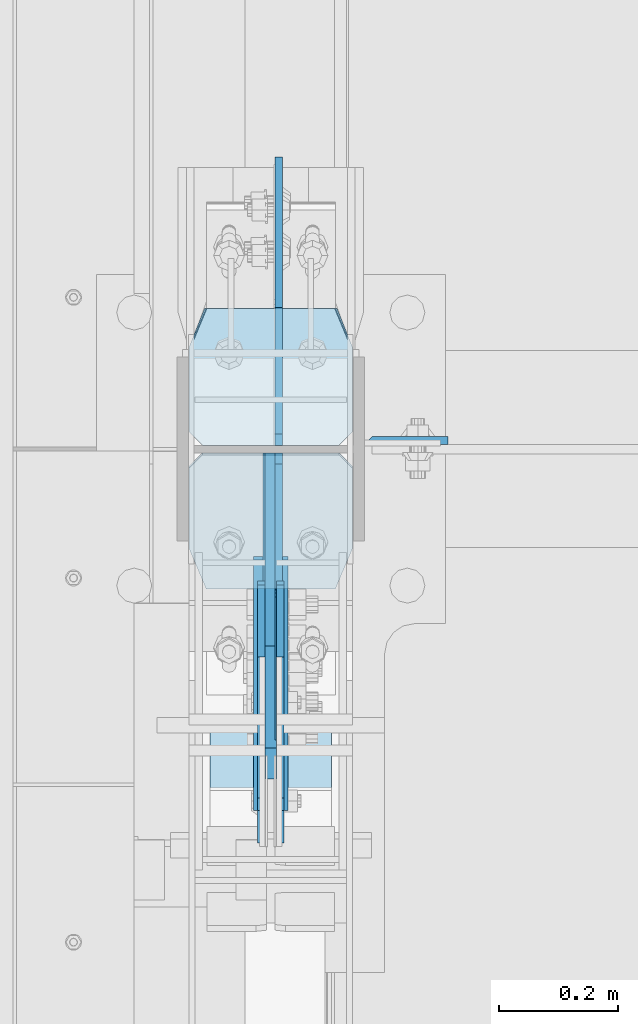
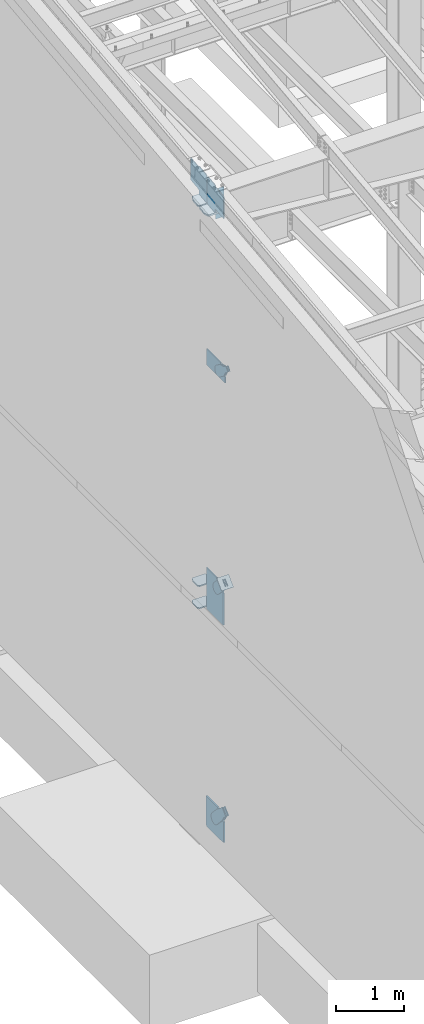
# One storey, part 1016 of 1179: 17 plates, 8 elements without a shape of their own.
"""IFC2X3 building model written with IfcOpenShell, lengths in millimetres."""

from ifc_helpers import new_model, si_unit, frame, origin_with_axes, place, context, subcontext, project, spatial, faceted_brep, material, type_object, element, aggregate, save


model = new_model("IFC2X3")

# Units and contexts
model_context = context("Model", 3, precision=1e-05, world=origin_with_axes())
body_context = subcontext(model_context, "Body", "Model", "MODEL_VIEW")
ifc_project = project(units=[si_unit("LENGTHUNIT", "METRE", prefix="MILLI"), si_unit("AREAUNIT", "SQUARE_METRE"), si_unit("VOLUMEUNIT", "CUBIC_METRE"), si_unit("MASSUNIT", "GRAM", prefix="KILO"), si_unit("TIMEUNIT", "SECOND"), si_unit("PLANEANGLEUNIT", "RADIAN"), si_unit("SOLIDANGLEUNIT", "STERADIAN"), si_unit("THERMODYNAMICTEMPERATUREUNIT", "DEGREE_CELSIUS"), si_unit("LUMINOUSINTENSITYUNIT", "LUMEN")], contexts=[model_context])

# Site, building, storey
site_placement = place(None, origin_with_axes())
site = spatial("IfcSite", under=ifc_project, at=site_placement, CompositionType="ELEMENT")
building_placement = place(site_placement, origin_with_axes())
building = spatial("IfcBuilding", under=site, at=building_placement, Name="Undefined", CompositionType="ELEMENT")
storey_placement = place(building_placement, origin_with_axes())
storey = spatial("IfcBuildingStorey", under=building, at=storey_placement, Name="Undefined", CompositionType="ELEMENT", Elevation=0.0)

# Assembly, plate
assembly_1_placement = place(storey_placement, origin_with_axes())
assembly_1 = element("IfcElementAssembly", 1, at=assembly_1_placement, inside=storey, Name="COLUMN", AssemblyPlace="NOTDEFINED", PredefinedType="RIGID_FRAME")
ifc_material_1 = material(Name="STEEL/A36")
plate_type_1 = type_object("IfcPlateType", PredefinedType="NOTDEFINED")
plate_1_placement = place(assembly_1_placement, frame((588.9625, 19242.0874999987, 11089.4812496185), z_axis=(0.0, 0.0, -1.0), x_axis=(1.0, 0.0, 0.0)))
plate_1 = element("IfcPlate", 2, at=plate_1_placement, type_object=plate_type_1, material=ifc_material_1, Name="PLATE", context=body_context, shape_type="Brep", body=[
    faceted_brep([(0.0, 6.34999999999854, 0.0), (12.7, -6.35000000000036, 0.0), (12.7, -6.35000000000036, 533.4), (0.0, 6.35000000000036, 533.4), (139.700000000001, -6.35000000000036, 533.4), (139.700000000001, 6.35000000000036, 533.4), (139.699999999997, -6.35000000000036, 0.0), (139.699999999997, 6.35000000000036, 0.0)], [[[0, 1, 2, 3]], [[4, 5, 3, 2]], [[4, 6, 7, 5]], [[7, 6, 1, 0]], [[5, 7, 0, 3]], [[6, 4, 2, 1]]]),
])

assembly_2_placement = place(storey_placement, origin_with_axes())
assembly_2 = element("IfcElementAssembly", 3, at=assembly_2_placement, inside=storey, AssemblyPlace="NOTDEFINED", PredefinedType="RIGID_FRAME")
plate_type_2 = type_object("IfcPlateType", PredefinedType="NOTDEFINED")
plate_2_placement = place(assembly_2_placement, frame((415.925000000002, 18622.7873418808, 8362.36497641817), z_axis=(0.0, -0.591856615182529, -0.80604326624858), x_axis=(0.0, 0.806043266248581, -0.591856615182529)))
plate_2 = element("IfcPlate", 4, at=plate_2_placement, type_object=plate_type_2, material=ifc_material_1, context=body_context, shape_type="Brep", body=[
    faceted_brep([(0.0, -6.34999999999854, 0.0), (-8.18545231595635e-11, -6.34999999999854, 91.5986124346418), (-8.18545231595635e-11, 6.34999999999854, 91.5986124346418), (0.0, 6.34999999999854, 0.0), (82.5500000001266, -6.34999999999854, 91.5986124347546), (82.5500000001266, 6.34999999999854, 91.5986124347546), (184.150000000493, -6.34999999999854, 136.286806217293), (184.150000000493, 6.34999999999854, 136.286806217293), (329.234985848627, -6.34999999999854, 136.286806217511), (329.234985848627, 6.34999999999854, 136.286806217511), (363.86305410257, -6.34999999999854, 129.398855183379), (363.86305410257, 6.34999999999854, 129.398855183379), (393.219312869078, -6.34999999999854, 109.783630186394), (393.219312869078, 6.34999999999854, 109.783630186394), (412.8345378661, -6.34999999999854, 80.4273714198789), (412.8345378661, 6.34999999999854, 80.4273714198789), (419.72248890029, -6.34999999999854, 45.7993092699908), (419.72248890029, 6.34999999999854, 45.7993092699908), (412.834537866132, -6.34999999999854, 11.171241015978), (412.834537866132, 6.34999999999854, 11.171241015978), (393.219312869132, -6.34999999999854, -18.1850177505985), (393.219312869132, 6.34999999999854, -18.1850177505985), (363.863054102636, -6.34999999999854, -37.8002427476786), (363.863054102636, 6.34999999999854, -37.8002427476786), (329.234988900062, -6.34999999999854, -44.6881937819198), (329.234988900062, 6.34999999999854, -44.6881937819198), (184.150000000598, -6.34999999999854, -44.6881937821345), (184.150000000598, 6.34999999999854, -44.6881937821345), (82.550000000203, -6.34999999999854, 1.2732925824821e-10), (82.550000000203, 6.34999999999854, 1.2732925824821e-10)], [[[0, 1, 2, 3]], [[1, 4, 5, 2]], [[4, 6, 7, 5]], [[6, 8, 9, 7]], [[8, 10, 11, 9]], [[10, 12, 13, 11]], [[12, 14, 15, 13]], [[14, 16, 17, 15]], [[16, 18, 19, 17]], [[18, 20, 21, 19]], [[20, 22, 23, 21]], [[22, 24, 25, 23]], [[24, 26, 27, 25]], [[26, 28, 29, 27]], [[28, 0, 3, 29]], [[5, 7, 9, 11, 13, 15, 17, 19, 21, 23, 25, 27, 29, 3, 2]], [[28, 26, 24, 22, 20, 18, 16, 14, 12, 10, 8, 6, 4, 1, 0]]]),
])
aggregate(assembly_2, [plate_2])

assembly_3_placement = place(storey_placement, origin_with_axes())
assembly_3 = element("IfcElementAssembly", 5, at=assembly_3_placement, inside=storey, AssemblyPlace="NOTDEFINED", PredefinedType="RIGID_FRAME")
plate_3_placement = place(assembly_3_placement, frame((447.675000000002, 18622.7873418808, 8362.36497641817), z_axis=(0.0, -0.591856615182529, -0.80604326624858), x_axis=(0.0, 0.806043266248581, -0.591856615182529)))
plate_3 = element("IfcPlate", 6, at=plate_3_placement, type_object=plate_type_2, material=ifc_material_1, context=body_context, shape_type="Brep", body=[
    faceted_brep([(0.0, -6.34999999999854, 0.0), (-8.18545231595635e-11, -6.34999999999854, 91.5986124346418), (-8.18545231595635e-11, 6.34999999999854, 91.5986124346418), (0.0, 6.34999999999854, 0.0), (82.5500000001266, -6.34999999999854, 91.5986124347546), (82.5500000001266, 6.34999999999854, 91.5986124347546), (184.150000000493, -6.34999999999854, 136.286806217293), (184.150000000493, 6.34999999999854, 136.286806217293), (329.234985848627, -6.34999999999854, 136.286806217511), (329.234985848627, 6.34999999999854, 136.286806217511), (363.86305410257, -6.34999999999854, 129.398855183379), (363.86305410257, 6.34999999999854, 129.398855183379), (393.219312869078, -6.34999999999854, 109.783630186394), (393.219312869078, 6.34999999999854, 109.783630186394), (412.8345378661, -6.34999999999854, 80.4273714198789), (412.8345378661, 6.34999999999854, 80.4273714198789), (419.72248890029, -6.34999999999854, 45.7993092699908), (419.72248890029, 6.34999999999854, 45.7993092699908), (412.834537866132, -6.34999999999854, 11.171241015978), (412.834537866132, 6.34999999999854, 11.171241015978), (393.219312869132, -6.34999999999854, -18.1850177505985), (393.219312869132, 6.34999999999854, -18.1850177505985), (363.863054102636, -6.34999999999854, -37.8002427476786), (363.863054102636, 6.34999999999854, -37.8002427476786), (329.234988900062, -6.34999999999854, -44.6881937819198), (329.234988900062, 6.34999999999854, -44.6881937819198), (184.150000000598, -6.34999999999854, -44.6881937821345), (184.150000000598, 6.34999999999854, -44.6881937821345), (82.550000000203, -6.34999999999854, 1.2732925824821e-10), (82.550000000203, 6.34999999999854, 1.2732925824821e-10)], [[[0, 1, 2, 3]], [[1, 4, 5, 2]], [[4, 6, 7, 5]], [[6, 8, 9, 7]], [[8, 10, 11, 9]], [[10, 12, 13, 11]], [[12, 14, 15, 13]], [[14, 16, 17, 15]], [[16, 18, 19, 17]], [[18, 20, 21, 19]], [[20, 22, 23, 21]], [[22, 24, 25, 23]], [[24, 26, 27, 25]], [[26, 28, 29, 27]], [[28, 0, 3, 29]], [[5, 7, 9, 11, 13, 15, 17, 19, 21, 23, 25, 27, 29, 3, 2]], [[28, 26, 24, 22, 20, 18, 16, 14, 12, 10, 8, 6, 4, 1, 0]]]),
])
aggregate(assembly_3, [plate_3])

assembly_4_placement = place(storey_placement, origin_with_axes())
assembly_4 = element("IfcElementAssembly", 7, at=assembly_4_placement, inside=storey, Name="Plate", AssemblyPlace="NOTDEFINED", PredefinedType="RIGID_FRAME")
plate_type_3 = type_object("IfcPlateType", PredefinedType="NOTDEFINED")
plate_4_placement = place(assembly_4_placement, frame((330.200000000002, 18613.493422613, 4376.50104380949), z_axis=(0.0, 0.71564233903776, 0.698466923036849), x_axis=(1.0, 0.0, 0.0)))
plate_4 = element("IfcPlate", 8, at=plate_4_placement, type_object=plate_type_3, material=ifc_material_1, Name="Plate", context=body_context, shape_type="Brep", body=[
    faceted_brep([(0.0, -3.17500000000109, 0.0), (0.0, -3.17500000000291, 203.200000000368), (0.0, 3.17499999998836, 203.200000000361), (0.0, 3.17500000000109, 7.27595761418343e-12), (203.199999999997, -3.17500000000291, 203.200000000368), (203.199999999997, 3.17499999998836, 203.200000000361), (203.199999999997, -3.17499999999927, 3.63797880709171e-12), (203.199999999997, 3.17499999999382, -3.63797880709171e-12)], [[[0, 1, 2, 3]], [[1, 4, 5, 2]], [[4, 6, 7, 5]], [[6, 0, 3, 7]], [[5, 7, 3, 2]], [[6, 4, 1, 0]]]),
])
aggregate(assembly_4, [plate_4])

# Plate
ifc_material_2 = material(Name="STEEL/A572-GR.50")
plate_type_4 = type_object("IfcPlateType", PredefinedType="NOTDEFINED")
plate_5_placement = place(assembly_1_placement, frame((568.325000000002, 19462.75, 3694.1125), z_axis=(-1.0, 0.0, 0.0), x_axis=(0.0, -1.0, 0.0)))
plate_5 = element("IfcPlate", 9, at=plate_5_placement, type_object=plate_type_4, material=ifc_material_2, Name="PLATE", context=body_context, shape_type="Brep", body=[
    faceted_brep([(0.0, -11.1125000000002, 247.650000381473), (63.5, -11.1125000000002, 273.050000000003), (63.5, 11.1125000000002, 273.050000000003), (0.0, 11.1125000000002, 247.650000381473), (63.5, -11.1125000000002, 0.0), (0.0, -11.1125000000002, 25.3999996185303), (0.0, 11.1125000000002, 25.3999996185303), (63.5, 11.1125000000002, 0.0), (206.374999618529, -11.1125000000002, 0.0), (206.374999618529, 11.1125000000002, 0.0), (228.599999999999, -11.1125000000002, 22.2250003814697), (228.599999999999, 11.1125000000002, 22.2250003814697), (228.599999999999, -11.1125000000002, 250.824999618533), (228.599999999999, 11.1125000000002, 250.824999618533), (206.374999618529, -11.1125000000002, 273.050000000003), (206.374999618529, 11.1125000000002, 273.050000000003)], [[[0, 1, 2, 3]], [[4, 5, 6, 7]], [[8, 4, 7, 9]], [[10, 8, 9, 11]], [[12, 10, 11, 13]], [[14, 12, 13, 15]], [[4, 8, 10, 12, 14, 1, 0, 5]], [[5, 0, 3, 6]], [[2, 15, 13, 11, 9, 7, 6, 3]], [[1, 14, 15, 2]]]),
])

plate_6_placement = place(assembly_1_placement, frame((568.325000000002, 19462.75, 4090.9875), z_axis=(-1.0, 0.0, 0.0), x_axis=(0.0, -1.0, 0.0)))
plate_6 = element("IfcPlate", 10, at=plate_6_placement, type_object=plate_type_4, material=ifc_material_2, Name="PLATE", context=body_context, shape_type="Brep", body=[
    faceted_brep([(0.0, -11.1125000000002, 247.650000381473), (63.5, -11.1125000000002, 273.050000000003), (63.5, 11.1125000000002, 273.050000000003), (0.0, 11.1125000000002, 247.650000381473), (63.5, -11.1125000000002, 0.0), (0.0, -11.1125000000002, 25.3999996185303), (0.0, 11.1125000000002, 25.3999996185303), (63.5, 11.1125000000002, 0.0), (206.374999618529, -11.1125000000002, 0.0), (206.374999618529, 11.1125000000002, 0.0), (228.599999999999, -11.1125000000002, 22.2250003814697), (228.599999999999, 11.1125000000002, 22.2250003814697), (228.599999999999, -11.1125000000002, 250.824999618533), (228.599999999999, 11.1125000000002, 250.824999618533), (206.374999618529, -11.1125000000002, 273.050000000003), (206.374999618529, 11.1125000000002, 273.050000000003)], [[[0, 1, 2, 3]], [[4, 5, 6, 7]], [[8, 4, 7, 9]], [[10, 8, 9, 11]], [[12, 10, 11, 13]], [[14, 12, 13, 15]], [[4, 8, 10, 12, 14, 1, 0, 5]], [[5, 0, 3, 6]], [[2, 15, 13, 11, 9, 7, 6, 3]], [[1, 14, 15, 2]]]),
])

plate_type_5 = type_object("IfcPlateType", PredefinedType="NOTDEFINED")
plate_7_placement = place(assembly_1_placement, frame((295.275000000099, 18991.1139131667, 10854.367675914), z_axis=(1.0, 0.0, 0.0), x_axis=(0.0, 0.993676146336441, 0.112284087038017)))
plate_7 = element("IfcPlate", 11, at=plate_7_placement, type_object=plate_type_5, material=ifc_material_2, Name="PLATE", context=body_context, shape_type="Brep", body=[
    faceted_brep([(207.962499617965, -14.2875000000749, 8.87325768417213e-11), (71.43750000002, -14.287499999984, 2.90469870378729e-11), (71.4375000000155, 14.2874999999949, 2.90469870378729e-11), (207.962499617975, 14.2874999999094, 8.87325768417213e-11), (230.187499999511, -14.287500000084, 22.225000381568), (230.187499999523, 14.2874999999003, 22.225000381568), (230.187500000431, -14.2875000000822, 250.824999623284), (230.187500000442, 14.2874999998985, 250.824999623284), (207.962499619063, -14.2875000000731, 273.050000004745), (207.962499619074, 14.2874999999112, 273.050000004745), (71.4375000016116, -14.2874999999858, 273.049999999798), (71.4375000016071, 14.2874999999967, 273.049999999798), (4.20737223302058, 14.2874999999931, 244.663945699182), (0.978435120117865, -14.2874999999894, 243.300616678719), (0.978435120117865, -14.2874999999894, 29.7493833255772), (4.20737223302058, 14.2874999999931, 28.3860543051127)], [[[0, 1, 2, 3]], [[4, 0, 3, 5]], [[6, 4, 5, 7]], [[8, 6, 7, 9]], [[10, 8, 9, 11]], [[10, 11, 12, 13]], [[1, 0, 4, 6, 8, 10, 13, 14]], [[2, 1, 14, 15]], [[11, 9, 7, 5, 3, 2, 15, 12]], [[14, 13, 12, 15]]]),
])

plate_type_6 = type_object("IfcPlateType", PredefinedType="NOTDEFINED")
plate_8_placement = place(assembly_1_placement, frame((568.325000000002, 19466.0635477106, 10908.0363549589), z_axis=(-1.0, 0.0, 0.0), x_axis=(0.0, -0.993676146336441, -0.112284087038017)))
plate_8 = element("IfcPlate", 12, at=plate_8_placement, type_object=plate_type_6, material=ifc_material_2, Name="PLATE", context=body_context, shape_type="Brep", body=[
    faceted_brep([(209.549999618157, -14.287499999904, 0.0), (73.0250015258425, -14.2874999999603, 0.0), (73.0250015258298, 14.2875000000258, 0.0), (209.549999618144, 14.2875000000804, 0.0), (231.774999999612, -14.2874999998949, 22.2250003814697), (231.774999999603, 14.2875000000895, 22.2250003814697), (231.774999999612, -14.2874999998949, 250.824999618533), (231.774999999603, 14.2875000000895, 250.824999618533), (209.549999618157, -14.287499999904, 273.050000000002), (209.549999618144, 14.2875000000804, 273.050000000002), (73.0250015258425, -14.2874999999603, 273.049999999998), (73.0250015258298, 14.2875000000258, 273.049999999998), (4.15974163581814, -14.2874999999876, 244.605653758279), (4.15974163581814, -14.2874999999876, 28.4443462417166), (0.930804522917242, 14.2874999999949, 29.7780376469105), (0.930804522917242, 14.2874999999949, 243.271962353085)], [[[0, 1, 2, 3]], [[4, 0, 3, 5]], [[6, 4, 5, 7]], [[8, 6, 7, 9]], [[10, 8, 9, 11]], [[1, 0, 4, 6, 8, 10, 12, 13]], [[2, 1, 13, 14]], [[11, 9, 7, 5, 3, 2, 14, 15]], [[10, 11, 15, 12]], [[14, 13, 12, 15]]]),
])

plate_type_7 = type_object("IfcPlateType", PredefinedType="NOTDEFINED")
plate_9_placement = place(assembly_1_placement, frame((445.293750000002, 19234.1499999787, 10915.2285667482), z_axis=(0.0, 0.663574933899741, 0.748109822886957), x_axis=(0.0, 0.748109822886957, -0.663574933899741)))
plate_9 = element("IfcPlate", 13, at=plate_9_placement, type_object=plate_type_7, material=ifc_material_2, Name="PLATE", context=body_context, shape_type="Brep", body=[
    faceted_brep([(-303.295097973984, -6.35000000000002, 370.48099768483), (-303.403957414206, 6.35000000000002, 370.578958576811), (-303.504098483867, 6.35000000000002, 342.168708916848), (-303.504098483867, -6.35000000000002, 342.168708916848), (25.4641550948563, -6.35000000000002, 0.0), (0.0, -6.34999999999854, 0.0), (0.0, 6.34999999999854, 0.0), (25.4641550948563, 6.35000000000002, 0.0), (167.045917247172, -6.35000000000002, 157.353263970723), (167.045917247172, 6.35000000000002, 157.353263970723), (131.563526715495, -6.35000000000002, 197.355899250204), (131.563526715495, 6.35000000000002, 197.355899250204), (126.802866418006, -6.35000000000002, 205.238730036501), (126.802866418006, 6.35000000000002, 205.238730036501), (125.165683086001, -6.35000000000002, 214.300878700633), (125.165683086001, 6.35000000000002, 214.300878700633), (126.867175912115, -6.35000000000002, 223.351173161929), (126.867175912115, 6.35000000000002, 223.351173161929), (131.683692556814, -6.35000000000002, 231.199999512715), (131.683692556814, 6.35000000000002, 231.199999512715), (286.794657668127, -6.35000000000002, 403.589566389341), (286.794657668127, 6.35000000000002, 403.589566389341), (23.8827060644498, -6.35000000000002, 699.99493122035), (23.8827060644498, 6.35000000000002, 699.99493122035), (-127.388721232707, -6.35000000000002, 531.872607863961), (-127.388721232707, 6.35000000000002, 531.872607863961), (-134.060951024564, -6.35000000000002, 526.588932486246), (-134.060951024564, 6.35000000000002, 526.588932486246), (-142.104023886786, -6.35000000000002, 523.805974558898), (-142.104023886786, 6.35000000000002, 523.805974558898), (-150.614897093323, -6.35000000000002, 523.836193008534), (-150.614897093323, 6.35000000000002, 523.836193008534), (-158.638005243585, -6.35000000000002, 526.676195033468), (-158.638005243585, 6.35000000000002, 526.676195033468), (-161.131532852267, 6.35000000000002, 528.679769861075), (-161.131532852267, -6.35000000000002, 528.679769861075)], [[[0, 1, 2, 3]], [[4, 5, 6, 7]], [[8, 4, 7, 9]], [[10, 8, 9, 11]], [[12, 10, 11, 13]], [[14, 12, 13, 15]], [[16, 14, 15, 17]], [[18, 16, 17, 19]], [[20, 18, 19, 21]], [[22, 20, 21, 23]], [[24, 22, 23, 25]], [[26, 24, 25, 27]], [[28, 26, 27, 29]], [[30, 28, 29, 31]], [[32, 30, 31, 33]], [[32, 33, 34, 35]], [[5, 4, 8, 10, 12, 14, 16, 18, 20, 22, 24, 26, 28, 30, 32, 35, 0, 3]], [[6, 5, 3, 2]], [[34, 33, 31, 29, 27, 25, 23, 21, 19, 17, 15, 13, 11, 9, 7, 6, 2, 1]], [[35, 34, 1, 0]]]),
])

plate_type_8 = type_object("IfcPlateType", PredefinedType="NOTDEFINED")
plate_10_placement = place(assembly_1_placement, frame((445.293750000002, 19221.45, 10913.428379323), z_axis=(0.0, -0.743858433013958, 0.668337214012522), x_axis=(0.0, -0.668337214012522, -0.743858433013957)))
plate_10 = element("IfcPlate", 14, at=plate_10_placement, type_object=plate_type_8, material=ifc_material_2, Name="PLATE", context=body_context, shape_type="Brep", body=[
    faceted_brep([(-340.371113907902, -6.35000000000002, 331.253164785625), (-340.423660034066, 6.35000000000002, 331.312311983026), (-340.496288379261, 6.35000000000002, 305.926948789638), (-340.496288379261, -6.35000000000002, 305.926948789638), (28.5035613092805, -6.35000000000002, -1.04591890703887e-11), (0.0, -6.34999999999854, 0.0), (0.0, 6.34999999999854, 0.0), (28.5035613092805, 6.35000000000002, -1.04591890703887e-11), (185.535041792471, -6.35000000000002, 139.488379402524), (185.535041792471, 6.35000000000002, 139.488379402524), (150.391206739107, -6.35000000000002, 171.064189752232), (150.391206739107, 6.35000000000002, 171.064189752232), (145.102749755571, -6.35000000000002, 177.732630246504), (145.102749755571, 6.35000000000002, 177.732630246504), (142.314026896069, -6.35000000000002, 185.773706089029), (142.314026896069, 6.35000000000002, 185.773706089029), (142.338144349787, -6.35000000000002, 194.28459877081), (142.338144349787, 6.35000000000002, 194.28459877081), (145.172394309466, -6.35000000000002, 202.30974070466), (145.172394309466, 6.35000000000002, 202.30974070466), (150.498558992693, -6.35000000000002, 208.948102374491), (150.498558992693, 6.35000000000002, 208.948102374491), (319.572465694362, -6.35000000000002, 359.133576332748), (319.572465694362, 6.35000000000002, 359.133576332748), (24.8516291671876, -6.35000000000002, 623.932487042394), (24.8516291671876, 6.35000000000002, 623.932487042394), (-148.513946545472, -6.35000000000002, 469.934796538949), (-148.513946545472, 6.35000000000002, 469.934796538949), (-156.393362644572, -6.35000000000002, 465.168486686387), (-156.393362644572, 6.35000000000002, 465.168486686387), (-165.454335371476, -6.35000000000002, 463.524807607098), (-165.454335371476, 6.35000000000002, 463.524807607098), (-174.505847216309, -6.35000000000002, 465.219812325748), (-174.505847216309, 6.35000000000002, 465.219812325748), (-182.358124252696, -6.35000000000002, 470.030701330617), (-182.358124252696, 6.35000000000002, 470.030701330617), (-183.313079553001, 6.35000000000002, 470.888703537204), (-183.313079553001, -6.35000000000002, 470.888703537204)], [[[0, 1, 2, 3]], [[4, 5, 6, 7]], [[8, 4, 7, 9]], [[10, 8, 9, 11]], [[12, 10, 11, 13]], [[14, 12, 13, 15]], [[16, 14, 15, 17]], [[18, 16, 17, 19]], [[20, 18, 19, 21]], [[22, 20, 21, 23]], [[24, 22, 23, 25]], [[26, 24, 25, 27]], [[28, 26, 27, 29]], [[30, 28, 29, 31]], [[32, 30, 31, 33]], [[34, 32, 33, 35]], [[34, 35, 36, 37]], [[5, 4, 8, 10, 12, 14, 16, 18, 20, 22, 24, 26, 28, 30, 32, 34, 37, 0, 3]], [[6, 5, 3, 2]], [[36, 35, 33, 31, 29, 27, 25, 23, 21, 19, 17, 15, 13, 11, 9, 7, 6, 2, 1]], [[37, 36, 1, 0]]]),
])

# Assembly, plate
assembly_5_placement = place(storey_placement, origin_with_axes())
assembly_5 = element("IfcElementAssembly", 15, at=assembly_5_placement, inside=storey, AssemblyPlace="NOTDEFINED", PredefinedType="RIGID_FRAME")
plate_type_9 = type_object("IfcPlateType", PredefinedType="NOTDEFINED")
plate_11_placement = place(assembly_5_placement, frame((415.925000000002, 18724.1271949212, 4488.91617933102), z_axis=(0.0, -0.715642339037757, -0.698466923036852), x_axis=(0.0, 0.698466923036852, -0.715642339037758)))
plate_11 = element("IfcPlate", 16, at=plate_11_placement, type_object=plate_type_9, material=ifc_material_1, context=body_context, shape_type="Brep", body=[
    faceted_brep([(0.0, -6.34999999999854, 0.0), (-4.35647962149233e-10, -6.34999999999854, 112.184930806416), (-4.35647962149233e-10, 6.34999999999854, 112.184930806416), (0.0, 6.34999999999854, 0.0), (82.5499999996491, -6.34999999999854, 112.184930806461), (82.5499999996491, 6.34999999999854, 112.184930806461), (184.149999999618, -6.34999999999854, 149.75496540347), (184.149999999618, 6.34999999999854, 149.75496540347), (327.919242323534, -6.34999999999854, 149.754965403559), (327.919242323534, 6.34999999999854, 149.754965403559), (363.762328723451, -6.34999999999854, 142.625332233587), (363.762328723451, 6.34999999999854, 142.625332233587), (394.148630137406, -6.34999999999854, 122.321854743475), (394.148630137406, 6.34999999999854, 122.321854743475), (414.452107627645, -6.34999999999854, 91.9355533295929), (414.452107627645, 6.34999999999854, 91.9355533295929), (421.581740797776, -6.34999999999854, 56.0924638777396), (421.581740797776, 6.34999999999854, 56.0924638777396), (414.452107627878, -6.34999999999854, 20.2493774776722), (414.452107627878, 6.34999999999854, 20.2493774776722), (394.14863013775, -6.34999999999854, -10.1369239363994), (394.14863013775, 6.34999999999854, -10.1369239363994), (363.762328723789, -6.34999999999854, -30.4404014266784), (363.762328723789, 6.34999999999854, -30.4404014266784), (327.919240798041, -6.34999999999854, -37.570034596738), (327.919240798041, 6.34999999999854, -37.570034596738), (184.150000000338, -6.34999999999854, -37.5700345968289), (184.150000000338, 6.34999999999854, -37.5700345968289), (82.550000000203, -6.34999999999854, 1.2732925824821e-10), (82.550000000203, 6.34999999999854, 1.2732925824821e-10)], [[[0, 1, 2, 3]], [[1, 4, 5, 2]], [[4, 6, 7, 5]], [[6, 8, 9, 7]], [[8, 10, 11, 9]], [[10, 12, 13, 11]], [[12, 14, 15, 13]], [[14, 16, 17, 15]], [[16, 18, 19, 17]], [[18, 20, 21, 19]], [[20, 22, 23, 21]], [[22, 24, 25, 23]], [[24, 26, 27, 25]], [[26, 28, 29, 27]], [[28, 0, 3, 29]], [[5, 7, 9, 11, 13, 15, 17, 19, 21, 23, 25, 27, 29, 3, 2]], [[28, 26, 24, 22, 20, 18, 16, 14, 12, 10, 8, 6, 4, 1, 0]]]),
])
aggregate(assembly_5, [plate_11])

assembly_6_placement = place(storey_placement, origin_with_axes())
assembly_6 = element("IfcElementAssembly", 17, at=assembly_6_placement, inside=storey, AssemblyPlace="NOTDEFINED", PredefinedType="RIGID_FRAME")
plate_12_placement = place(assembly_6_placement, frame((447.675000000002, 18724.1271949212, 4488.91617933102), z_axis=(0.0, -0.715642339037757, -0.698466923036852), x_axis=(0.0, 0.698466923036852, -0.715642339037758)))
plate_12 = element("IfcPlate", 18, at=plate_12_placement, type_object=plate_type_9, material=ifc_material_1, context=body_context, shape_type="Brep", body=[
    faceted_brep([(0.0, -6.34999999999854, 0.0), (-4.35647962149233e-10, -6.34999999999854, 112.184930806416), (-4.35647962149233e-10, 6.34999999999854, 112.184930806416), (0.0, 6.34999999999854, 0.0), (82.5499999996491, -6.34999999999854, 112.184930806461), (82.5499999996491, 6.34999999999854, 112.184930806461), (184.149999999618, -6.34999999999854, 149.75496540347), (184.149999999618, 6.34999999999854, 149.75496540347), (327.919242323534, -6.34999999999854, 149.754965403559), (327.919242323534, 6.34999999999854, 149.754965403559), (363.762328723451, -6.34999999999854, 142.625332233587), (363.762328723451, 6.34999999999854, 142.625332233587), (394.148630137406, -6.34999999999854, 122.321854743475), (394.148630137406, 6.34999999999854, 122.321854743475), (414.452107627645, -6.34999999999854, 91.9355533295929), (414.452107627645, 6.34999999999854, 91.9355533295929), (421.581740797776, -6.34999999999854, 56.0924638777396), (421.581740797776, 6.34999999999854, 56.0924638777396), (414.452107627878, -6.34999999999854, 20.2493774776722), (414.452107627878, 6.34999999999854, 20.2493774776722), (394.14863013775, -6.34999999999854, -10.1369239363994), (394.14863013775, 6.34999999999854, -10.1369239363994), (363.762328723789, -6.34999999999854, -30.4404014266784), (363.762328723789, 6.34999999999854, -30.4404014266784), (327.919240798041, -6.34999999999854, -37.570034596738), (327.919240798041, 6.34999999999854, -37.570034596738), (184.150000000338, -6.34999999999854, -37.5700345968289), (184.150000000338, 6.34999999999854, -37.5700345968289), (82.550000000203, -6.34999999999854, 1.2732925824821e-10), (82.550000000203, 6.34999999999854, 1.2732925824821e-10)], [[[0, 1, 2, 3]], [[1, 4, 5, 2]], [[4, 6, 7, 5]], [[6, 8, 9, 7]], [[8, 10, 11, 9]], [[10, 12, 13, 11]], [[12, 14, 15, 13]], [[14, 16, 17, 15]], [[16, 18, 19, 17]], [[18, 20, 21, 19]], [[20, 22, 23, 21]], [[22, 24, 25, 23]], [[24, 26, 27, 25]], [[26, 28, 29, 27]], [[28, 0, 3, 29]], [[5, 7, 9, 11, 13, 15, 17, 19, 21, 23, 25, 27, 29, 3, 2]], [[28, 26, 24, 22, 20, 18, 16, 14, 12, 10, 8, 6, 4, 1, 0]]]),
])
aggregate(assembly_6, [plate_12])

# Plate
plate_type_10 = type_object("IfcPlateType", PredefinedType="NOTDEFINED")
plate_13_placement = place(assembly_1_placement, frame((431.800000000002, 19221.45, 8026.4), z_axis=(0.0, 0.0, 1.0), x_axis=(0.0, -1.0, 0.0)))
plate_13 = element("IfcPlate", 19, at=plate_13_placement, type_object=plate_type_10, material=ifc_material_2, Name="PLATE", context=body_context, shape_type="Brep", body=[
    faceted_brep([(0.0, -9.52500000000146, 19.0499992370605), (0.0, -9.52499999999998, 283.468697373038), (0.0, 9.52499999999998, 283.468697373038), (0.0, 9.52500000000146, 19.0499992370605), (408.747629502155, -9.52499999999998, 283.468697373038), (408.747629502155, 9.52499999999998, 283.468697373038), (545.925196486085, -9.52499999999998, 96.6480193382731), (545.925196486085, 9.52499999999998, 96.6480193382731), (545.925196486085, -9.52499999999998, 0.0), (545.925196486085, 9.52499999999998, 0.0), (19.0499992370605, -9.52500000000146, 0.0), (19.0499992370605, 9.52500000000146, 0.0)], [[[0, 1, 2, 3]], [[1, 4, 5, 2]], [[4, 6, 7, 5]], [[6, 8, 9, 7]], [[8, 10, 11, 9]], [[10, 0, 3, 11]], [[5, 7, 9, 11, 3, 2]], [[10, 8, 6, 4, 1, 0]]]),
])

plate_type_11 = type_object("IfcPlateType", PredefinedType="NOTDEFINED")
plate_14_placement = place(assembly_1_placement, frame((431.800000000002, 19221.45, 3663.950000377), z_axis=(0.0, 0.0, 1.0), x_axis=(0.0, -1.0, 0.0)))
plate_14 = element("IfcPlate", 20, at=plate_14_placement, type_object=plate_type_11, material=ifc_material_2, Name="PLATE", context=body_context, shape_type="Brep", body=[
    faceted_brep([(0.0, -9.52499999999964, 0.0), (-3.63797880709171e-12, -9.52499999999998, 737.163128918689), (-3.63797880709171e-12, 9.52499999999998, 737.163128918689), (0.0, 9.52499999999964, 0.0), (323.636098339506, -9.52499999999998, 737.163128918689), (323.636098339506, 9.52499999999998, 737.163128918689), (494.048430322873, -9.52499999999998, 570.84069287054), (494.048430322873, 9.52499999999998, 570.84069287054), (494.048430322877, -9.52499999999998, 0.0), (494.048430322877, 9.52499999999998, 0.0)], [[[0, 1, 2, 3]], [[1, 4, 5, 2]], [[4, 6, 7, 5]], [[6, 8, 9, 7]], [[8, 0, 3, 9]], [[5, 7, 9, 3, 2]], [[8, 6, 4, 1, 0]]]),
])

plate_type_12 = type_object("IfcPlateType", PredefinedType="NOTDEFINED")
plate_15_placement = place(assembly_1_placement, frame((431.800000000002, 19221.45, -215.9), z_axis=(0.0, 0.0, 1.0), x_axis=(0.0, -1.0, 0.0)))
plate_15 = element("IfcPlate", 21, at=plate_15_placement, type_object=plate_type_12, material=ifc_material_2, Name="PLATE", context=body_context, shape_type="Brep", body=[
    faceted_brep([(0.0, -12.7000000000007, 19.0500000000029), (0.0, -12.7, 534.018748335632), (0.0, 12.7, 534.018748335632), (0.0, 12.7000000000007, 19.0500000000029), (331.311918860847, -12.7, 534.018748335632), (331.311918860847, 12.7, 534.018748335632), (506.88311243628, -12.7, 368.487947617164), (506.88311243628, 12.7, 368.487947617164), (506.88311243628, -12.7, 0.0), (506.88311243628, 12.7, 0.0), (19.0499992370605, -12.6999999999971, 0.0), (19.0499992370605, 12.6999999999971, 0.0)], [[[0, 1, 2, 3]], [[1, 4, 5, 2]], [[4, 6, 7, 5]], [[6, 8, 9, 7]], [[8, 10, 11, 9]], [[10, 0, 3, 11]], [[5, 7, 9, 11, 3, 2]], [[10, 8, 6, 4, 1, 0]]]),
])

aggregate(assembly_1, [plate_8, plate_9, plate_7, plate_10, plate_13, plate_14, plate_15, plate_1, plate_5, plate_6])

# Assembly, plate
assembly_7_placement = place(storey_placement, origin_with_axes())
assembly_7 = element("IfcElementAssembly", 22, at=assembly_7_placement, inside=storey, AssemblyPlace="NOTDEFINED", PredefinedType="RIGID_FRAME")
plate_type_13 = type_object("IfcPlateType", PredefinedType="NOTDEFINED")
plate_16_placement = place(assembly_7_placement, frame((411.162500000002, 18729.4707277224, 419.729946485765), z_axis=(0.0, -0.727605443744034, -0.685995858758672), x_axis=(0.0, 0.685995858758672, -0.727605443744034)))
plate_16 = element("IfcPlate", 23, at=plate_16_placement, type_object=plate_type_13, material=ifc_material_1, context=body_context, shape_type="Brep", body=[
    faceted_brep([(0.0, -7.9375, 0.0), (-8.00355337560177e-11, -7.9375, 146.904840309817), (-8.00355337560177e-11, 7.9375, 146.904840309817), (0.0, 7.9375, 0.0), (82.5499999998137, -7.9375, 146.90484031055), (82.5499999998137, 7.9375, 146.90484031055), (184.150000000214, -7.9375, 168.702420155054), (184.150000000214, 7.9375, 168.702420155054), (403.471138850085, -7.9375, 168.70242015493), (403.471138850085, 7.9375, 168.70242015493), (439.921735782846, -7.9375, 161.451945626626), (439.921735782846, 7.9375, 161.451945626626), (470.823059758064, -7.9375, 140.804341062974), (470.823059758064, 7.9375, 140.804341062974), (491.470664321725, -7.9375, 109.903017087783), (491.470664321725, 7.9375, 109.903017087783), (498.721138850011, -7.9375, 73.4524201549993), (498.721138850011, 7.9375, 73.4524201549993), (491.470664321694, -7.9375, 37.001823222241), (491.470664321694, 7.9375, 37.001823222241), (470.82305975797, -7.9375, 6.10049924700979), (470.82305975797, 7.9375, 6.10049924700979), (439.921735782676, -7.9375, -14.5471053166548), (439.921735782676, 7.9375, -14.5471053166548), (403.471138849898, -7.9375, -21.7975798449352), (403.471138849898, 7.9375, -21.7975798449352), (184.150000000169, -7.9375, -21.7975798448115), (184.150000000169, 7.9375, -21.7975798448115), (82.5500000000975, -7.9375, -6.91215973347425e-11), (82.5500000000975, 7.9375, -6.91215973347425e-11)], [[[0, 1, 2, 3]], [[1, 4, 5, 2]], [[4, 6, 7, 5]], [[6, 8, 9, 7]], [[8, 10, 11, 9]], [[10, 12, 13, 11]], [[12, 14, 15, 13]], [[14, 16, 17, 15]], [[16, 18, 19, 17]], [[18, 20, 21, 19]], [[20, 22, 23, 21]], [[22, 24, 25, 23]], [[24, 26, 27, 25]], [[26, 28, 29, 27]], [[28, 0, 3, 29]], [[5, 7, 9, 11, 13, 15, 17, 19, 21, 23, 25, 27, 29, 3, 2]], [[28, 26, 24, 22, 20, 18, 16, 14, 12, 10, 8, 6, 4, 1, 0]]]),
])
aggregate(assembly_7, [plate_16])

assembly_8_placement = place(storey_placement, origin_with_axes())
assembly_8 = element("IfcElementAssembly", 24, at=assembly_8_placement, inside=storey, AssemblyPlace="NOTDEFINED", PredefinedType="RIGID_FRAME")
plate_17_placement = place(assembly_8_placement, frame((452.437500000002, 18729.4707277224, 419.729946485765), z_axis=(0.0, -0.727605443744034, -0.685995858758672), x_axis=(0.0, 0.685995858758672, -0.727605443744034)))
plate_17 = element("IfcPlate", 25, at=plate_17_placement, type_object=plate_type_13, material=ifc_material_1, context=body_context, shape_type="Brep", body=[
    faceted_brep([(0.0, -7.9375, 0.0), (-8.00355337560177e-11, -7.9375, 146.904840309817), (-8.00355337560177e-11, 7.9375, 146.904840309817), (0.0, 7.9375, 0.0), (82.5499999998137, -7.9375, 146.90484031055), (82.5499999998137, 7.9375, 146.90484031055), (184.150000000214, -7.9375, 168.702420155054), (184.150000000214, 7.9375, 168.702420155054), (403.471138850085, -7.9375, 168.70242015493), (403.471138850085, 7.9375, 168.70242015493), (439.921735782846, -7.9375, 161.451945626626), (439.921735782846, 7.9375, 161.451945626626), (470.823059758064, -7.9375, 140.804341062974), (470.823059758064, 7.9375, 140.804341062974), (491.470664321725, -7.9375, 109.903017087783), (491.470664321725, 7.9375, 109.903017087783), (498.721138850011, -7.9375, 73.4524201549993), (498.721138850011, 7.9375, 73.4524201549993), (491.470664321694, -7.9375, 37.001823222241), (491.470664321694, 7.9375, 37.001823222241), (470.82305975797, -7.9375, 6.10049924700979), (470.82305975797, 7.9375, 6.10049924700979), (439.921735782676, -7.9375, -14.5471053166548), (439.921735782676, 7.9375, -14.5471053166548), (403.471138849898, -7.9375, -21.7975798449352), (403.471138849898, 7.9375, -21.7975798449352), (184.150000000169, -7.9375, -21.7975798448115), (184.150000000169, 7.9375, -21.7975798448115), (82.5500000000975, -7.9375, -6.91215973347425e-11), (82.5500000000975, 7.9375, -6.91215973347425e-11)], [[[0, 1, 2, 3]], [[1, 4, 5, 2]], [[4, 6, 7, 5]], [[6, 8, 9, 7]], [[8, 10, 11, 9]], [[10, 12, 13, 11]], [[12, 14, 15, 13]], [[14, 16, 17, 15]], [[16, 18, 19, 17]], [[18, 20, 21, 19]], [[20, 22, 23, 21]], [[22, 24, 25, 23]], [[24, 26, 27, 25]], [[26, 28, 29, 27]], [[28, 0, 3, 29]], [[5, 7, 9, 11, 13, 15, 17, 19, 21, 23, 25, 27, 29, 3, 2]], [[28, 26, 24, 22, 20, 18, 16, 14, 12, 10, 8, 6, 4, 1, 0]]]),
])
aggregate(assembly_8, [plate_17])

save(model, "model.ifc")
